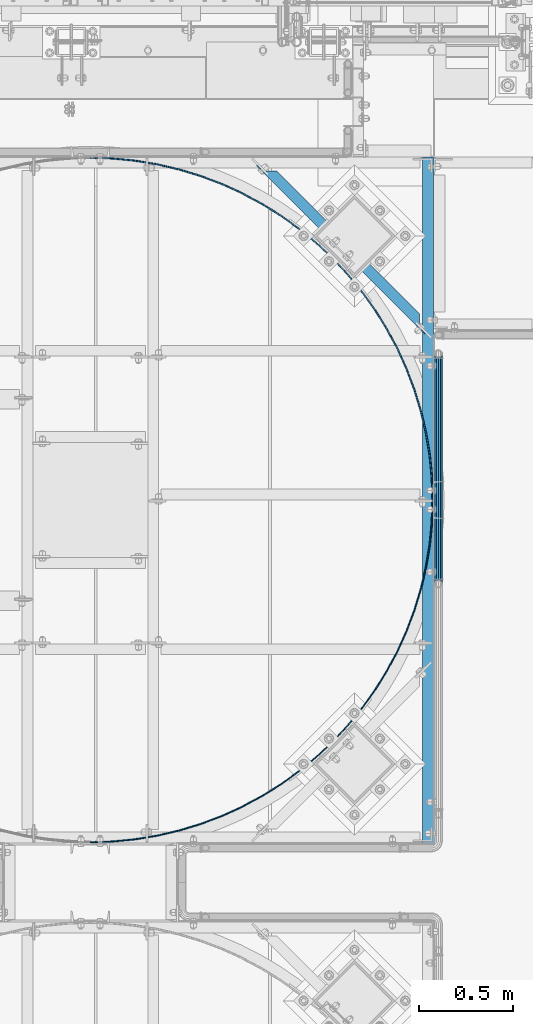
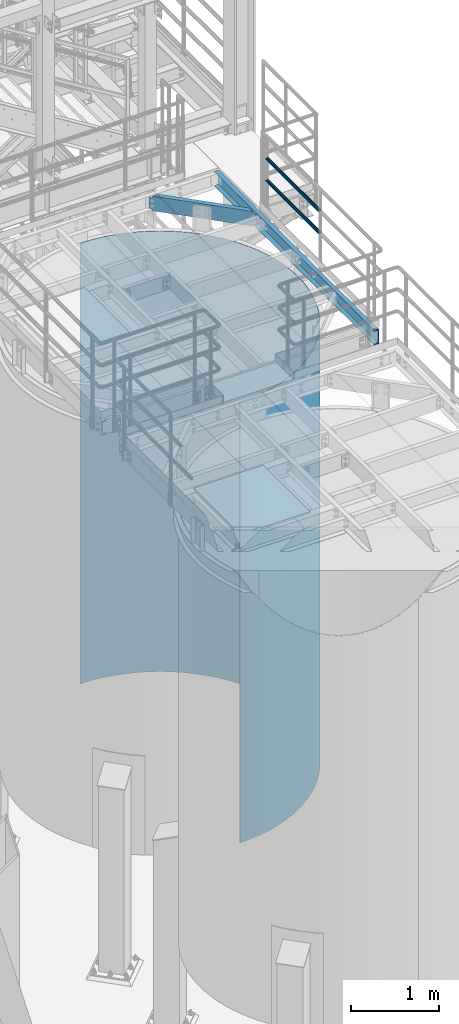
# One storey, part 942 of 1876: 5 beams, 4 elements without a shape of their own.
"""IFC2X3 building model written with IfcOpenShell, lengths in millimetres."""

import ifcopenshell
import ifcopenshell.guid

model = None  # the IFC model being written
_history = None  # IfcOwnerHistory: only IFC2X3 demands one
_inside = {}  # id of a spatial element -> (the spatial element, [elements in it])
_under = {}  # id of a project, library or spatial element -> (it, [spatial elements below it])
_declared = {}  # id of a project -> (the project, [libraries it declares])
_typed = {}  # id of a type object -> (the type object, [elements of that type])
_made_of = {}  # id of a material, layer set ... -> (it, [elements and type objects made of it])


def new_model(schema):
    """Start an empty IFC model of exactly this schema.

    Asked for "IFC4X3", IfcOpenShell would pick the latest addendum, in which some entities
    have other attributes; the version numbers below select the first issue.
    IFC2X3 requires an IfcOwnerHistory on every rooted entity: one is made here for all.
    """
    global model, _history
    if schema == "IFC4X3":
        model = ifcopenshell.file(schema_version=(4, 3, 0, 0))
    else:
        model = ifcopenshell.file(schema=schema)
    _inside.clear()
    _under.clear()
    _declared.clear()
    _typed.clear()
    _made_of.clear()
    _history = None
    if model.schema == "IFC2X3":
        org = make("IfcOrganization", Name="unknown")
        user = make(
            "IfcPersonAndOrganization",
            ThePerson=make("IfcPerson", FamilyName="unknown"),
            TheOrganization=org,
        )
        app = make(
            "IfcApplication",
            ApplicationDeveloper=org,
            Version="unknown",
            ApplicationFullName="unknown",
            ApplicationIdentifier="unknown",
        )
        _history = make(
            "IfcOwnerHistory",
            OwningUser=user,
            OwningApplication=app,
            ChangeAction="ADDED",
            CreationDate=0,
        )
    return model


def make(cls, **values):
    """One entity of the class cls with the attributes given. An attribute that is None is left unset."""
    return model.create_entity(
        cls, **{name: value for name, value in values.items() if value is not None}
    )


def rooted(cls, **values):
    """An entity with a GlobalId (a new one), such as an element, a storey or a relation."""
    return make(cls, GlobalId=ifcopenshell.guid.new(), OwnerHistory=_history, **values)


def si_unit(unit_type, name, prefix=None):
    """IfcSIUnit, for example si_unit("LENGTHUNIT", "METRE", prefix="MILLI")."""
    return make("IfcSIUnit", UnitType=unit_type, Prefix=prefix, Name=name)


def assignment(units):
    """IfcUnitAssignment: the units of a project."""
    return None if units is None else make("IfcUnitAssignment", Units=units)


def point(xyz):
    """IfcCartesianPoint."""
    return None if xyz is None else make("IfcCartesianPoint", Coordinates=xyz)


def direction(xyz):
    """IfcDirection."""
    return None if xyz is None else make("IfcDirection", DirectionRatios=xyz)


def frame(location, z_axis=None, x_axis=None):
    """IfcAxis2Placement3D, a coordinate frame: its origin and axes. An axis left out is left unset."""
    return make(
        "IfcAxis2Placement3D",
        Location=point(location),
        Axis=direction(z_axis),
        RefDirection=direction(x_axis),
    )


def origin_with_axes():
    """The frame at (0, 0, 0) with the z axis (0, 0, 1) and the x axis (1, 0, 0) written out."""
    return frame((0.0, 0.0, 0.0), z_axis=(0.0, 0.0, 1.0), x_axis=(1.0, 0.0, 0.0))


def place(relative_to, where):
    """IfcLocalPlacement: puts the frame where relative to a parent placement (None: the world)."""
    return make(
        "IfcLocalPlacement", PlacementRelTo=relative_to, RelativePlacement=where
    )


def context(
    kind, dimensions, precision=None, world=None, true_north=None, identifier=None
):
    """IfcGeometricRepresentationContext, for example the 3D "Model" context."""
    return make(
        "IfcGeometricRepresentationContext",
        ContextIdentifier=identifier,
        ContextType=kind,
        CoordinateSpaceDimension=dimensions,
        Precision=precision,
        WorldCoordinateSystem=world,
        TrueNorth=true_north,
    )


def subcontext(parent, identifier, kind, view, scale=None):
    """IfcGeometricRepresentationSubContext, for example "Body" below "Model"."""
    return make(
        "IfcGeometricRepresentationSubContext",
        ContextIdentifier=identifier,
        ContextType=kind,
        ParentContext=parent,
        TargetScale=scale,
        TargetView=view,
    )


def project(units=None, contexts=None):
    """IfcProject with its units and contexts."""
    return rooted(
        "IfcProject",
        Name="project",
        RepresentationContexts=contexts,
        UnitsInContext=assignment(units),
    )


def spatial(cls, under=None, at=None, **own):
    """A site, building, storey or space (cls), placed at a placement, below another one or the project."""
    s = rooted(cls, ObjectPlacement=at, **own)
    if under is not None:
        _under.setdefault(under.id(), (under, []))[1].append(s)
    return s


def faces_of(points, faces, orient=None, outer=None):
    """IfcFace entities. A face is a list of loops; a loop is a list of indices into points, from 0.

    orient and outer hold one flag for each loop. By default every Orientation is true, the
    first loop of a face is its IfcFaceOuterBound and the others are IfcFaceBound.
    """
    made = []
    for i, loops in enumerate(faces):
        bounds = []
        for j, loop in enumerate(loops):
            is_outer = j == 0 if outer is None else outer[i][j]
            bounds.append(
                make(
                    "IfcFaceOuterBound" if is_outer else "IfcFaceBound",
                    Bound=make("IfcPolyLoop", Polygon=[points[k] for k in loop]),
                    Orientation=True if orient is None else orient[i][j],
                )
            )
        made.append(make("IfcFace", Bounds=bounds))
    return made


def faceted_brep(points, faces, orient=None, outer=None, voids=None):
    """IfcFacetedBrep: a solid bounded by flat faces; with voids (closed shells), ...WithVoids."""
    shared = [point(p) for p in points]
    hull = make("IfcClosedShell", CfsFaces=faces_of(shared, faces, orient, outer))
    if voids is None:
        return make("IfcFacetedBrep", Outer=hull)
    return make(
        "IfcFacetedBrepWithVoids",
        Outer=hull,
        Voids=[
            make(cls, CfsFaces=faces_of(shared, fs, o, b)) for cls, fs, o, b in voids
        ],
    )


def shape(context_of_items, identifier, shape_type, items):
    """IfcShapeRepresentation: the items that make up one representation, for example the "Body"."""
    return make(
        "IfcShapeRepresentation",
        ContextOfItems=context_of_items,
        RepresentationIdentifier=identifier,
        RepresentationType=shape_type,
        Items=items,
    )


def material(Name=None, Category=None):
    """IfcMaterial."""
    return make("IfcMaterial", Name=Name, Category=Category)


def made_of(thing, what):
    """Note that an element or type object is made of a material, layer set ...; save() writes the relation."""
    if what is not None:
        _made_of.setdefault(what.id(), (what, []))[1].append(thing)
    return thing


def type_object(cls, material=None, **own):
    """A type object (cls), such as IfcWallType, which elements share."""
    return made_of(rooted(cls, **own), material)


def element(
    cls,
    number,
    at=None,
    inside=None,
    cuts=None,
    type_object=None,
    material=None,
    context=None,
    identifier="Body",
    shape_type=None,
    held_by="IfcProductDefinitionShape",
    body=None,
    shapes=None,
    **own,
):
    """One element of the class cls, such as IfcWall. Its Tag is "e" and its number.

    at: its placement. inside: the storey or other place that contains it. cuts: it is an
    opening in that element (IfcRelVoidsElement). A single representation is given by context,
    identifier, shape_type and body (its items); several are given by shapes. held_by: the class
    of the entity that holds the representations. save() writes the other relations.
    """
    e = rooted(cls, Tag="e%d" % number, ObjectPlacement=at, **own)
    if body is not None:
        shapes = [shape(context, identifier, shape_type, body)]
    if shapes is not None:
        e.Representation = make(held_by, Representations=shapes)
    if inside is not None:
        _inside.setdefault(inside.id(), (inside, []))[1].append(e)
    if cuts is not None:
        rooted(
            "IfcRelVoidsElement", RelatingBuildingElement=cuts, RelatedOpeningElement=e
        )
    if type_object is not None:
        _typed.setdefault(type_object.id(), (type_object, []))[1].append(e)
    return made_of(e, material)


def aggregate(whole, parts):
    """IfcRelAggregates: a whole, such as a stair, and the parts it consists of."""
    return rooted("IfcRelAggregates", RelatingObject=whole, RelatedObjects=parts)


def save(model, path):
    """Write the relations noted so far, then the file.

    IfcRelAggregates (storeys below a building ...), IfcRelContainedInSpatialStructure (elements
    in a storey), IfcRelDefinesByType, IfcRelAssociatesMaterial and IfcRelDeclares: one each for
    every whole, place, type object, material and project.
    """
    for whole, parts in _under.values():
        aggregate(whole, parts)
    for where, things in _inside.values():
        rooted(
            "IfcRelContainedInSpatialStructure",
            RelatedElements=things,
            RelatingStructure=where,
        )
    for kind, things in _typed.values():
        rooted("IfcRelDefinesByType", RelatedObjects=things, RelatingType=kind)
    for what, things in _made_of.values():
        rooted("IfcRelAssociatesMaterial", RelatedObjects=things, RelatingMaterial=what)
    for by, libraries in _declared.values():
        rooted("IfcRelDeclares", RelatingContext=by, RelatedDefinitions=libraries)
    model.write(path)


model = new_model("IFC2X3")

# Units and contexts
model_context = context("Model", 3, precision=1e-05, world=origin_with_axes())
body_context = subcontext(model_context, "Body", "Model", "MODEL_VIEW")
ifc_project = project(units=[si_unit("LENGTHUNIT", "METRE", prefix="MILLI"), si_unit("AREAUNIT", "SQUARE_METRE"), si_unit("VOLUMEUNIT", "CUBIC_METRE"), si_unit("MASSUNIT", "GRAM", prefix="KILO"), si_unit("TIMEUNIT", "SECOND"), si_unit("PLANEANGLEUNIT", "RADIAN"), si_unit("SOLIDANGLEUNIT", "STERADIAN"), si_unit("THERMODYNAMICTEMPERATUREUNIT", "DEGREE_CELSIUS"), si_unit("LUMINOUSINTENSITYUNIT", "LUMEN")], contexts=[model_context])

# Site, building, storey
site_placement = place(None, origin_with_axes())
site = spatial("IfcSite", under=ifc_project, at=site_placement, CompositionType="ELEMENT")
building_placement = place(site_placement, origin_with_axes())
building = spatial("IfcBuilding", under=site, at=building_placement, Name="Undefined", CompositionType="ELEMENT")
storey_placement = place(building_placement, origin_with_axes())
storey = spatial("IfcBuildingStorey", under=building, at=storey_placement, Name="Undefined", CompositionType="ELEMENT", Elevation=0.0)

# Assembly, beams
assembly_1_placement = place(storey_placement, origin_with_axes())
assembly_1 = element("IfcElementAssembly", 1, at=assembly_1_placement, inside=storey, Name="HANDRAIL", AssemblyPlace="NOTDEFINED", PredefinedType="RIGID_FRAME")
ifc_material_1 = material()
beam_type_1 = type_object("IfcBeamType", Name="PIPE1-1/4STD", PredefinedType="NOTDEFINED")
beam_1_placement = place(assembly_1_placement, frame((7025.13388293519, -9982.16435546873, 8480.425), z_axis=(0.0, 0.0, 1.0), x_axis=(0.0, 1.0, 0.0)))
beam_1 = element("IfcBeam", 2, at=beam_1_placement, type_object=beam_type_1, material=ifc_material_1, Name="RAIL", ObjectType="PIPE1-1/4STD", context=body_context, shape_type="Brep", body=[
    faceted_brep([(1200.94245243742, -10.5409999999993, 18.2575475625836), (1200.94245243742, -10.5409999999993, 13.3999612267253), (1200.46603877327, -8.76300000000083, 15.1779612267255), (1198.118, 0.0, 17.5259999999998), (1198.118, 0.0, 21.0820000000003), (1200.46603877327, 8.76300000000083, 15.1779612267255), (1200.94245243742, 10.5409999999993, 13.3999612267253), (1200.94245243742, 10.5409999999993, 18.2575475625836), (1219.2, 21.0820000000003, 0.0), (1208.659, 18.2575475625836, 10.5409999999993), (1208.659, 18.2575475625836, -10.5409999999993), (1205.57941366414, 15.1779612267255, 8.76300000000083), (1207.92745243742, 17.5259999999998, 0.0), (1205.57941366414, 15.1779612267255, -8.76300000000083), (1200.94245243742, 10.5409999999993, -13.3999612267253), (1200.94245243742, 10.5409999999993, -18.2575475625836), (1200.46603877327, 8.76300000000083, -15.1779612267255), (1198.118, 0.0, -17.5259999999998), (1198.118, 0.0, -21.0820000000003), (1200.94245243742, -10.5409999999993, -13.3999612267253), (1200.94245243742, -10.5409999999993, -18.2575475625836), (1200.46603877327, -8.76300000000083, -15.1779612267255), (1219.2, -21.0820000000003, 0.0), (1208.659, -18.2575475625836, -10.5409999999993), (1208.659, -18.2575475625836, 10.5409999999993), (1205.57941366414, -15.1779612267255, -8.76300000000083), (1207.92745243742, -17.5259999999998, 0.0), (1205.57941366414, -15.1779612267255, 8.76300000000083), (10.5409999957128, -18.2575475672238, -10.5409999999993), (18.2575475625817, -10.5410000000011, -18.2575475625836), (9.09494701772928e-13, 21.0820000000003, 0.0), (10.5409999957128, 18.2575475579433, -10.5409999999993), (10.5409999999983, 18.2575475625836, 10.5410000000011), (18.2575475625817, 10.5409999999993, 18.2575475625836), (21.0819999999985, 1.81898940354586e-12, 21.0820000000003), (18.2575475625817, 10.5409999999993, -18.2575475625836), (21.0819999999985, 0.0, -21.0819999999985), (21.0819999999985, 0.0, -17.5259999999998), (18.2575475625817, -10.5409999999974, -13.3999612267271), (18.7339612267233, -8.76300000000083, -15.1779612267255), (18.7339612267251, 8.76299999999901, -15.1779612267255), (18.2575475625817, 10.5410000000011, -13.3999612267235), (13.6205863358573, 15.1779612267255, -8.76299999999901), (11.2725475625839, 17.5259999999998, 0.0), (13.6205863358573, 15.1779612267255, 8.76300000000083), (18.2575475625817, 10.5410000000011, 13.3999612267253), (18.7339612267251, 8.76299999999901, 15.1779612267273), (21.0819999999985, 1.81898940354586e-12, 17.5259999999998), (18.7339612267233, -8.76300000000083, 15.1779612267273), (18.2575475625817, -10.5409999999974, 13.3999612267289), (18.2575475625817, -10.5410000000011, 18.2575475625836), (10.5409999999983, -18.2575475625836, 10.5410000000011), (9.09494701772928e-13, -21.0820000000003, 0.0), (13.6205863358537, -15.1779612267255, 8.76300000000083), (11.2725475625793, -17.5259999999998, 0.0), (13.6205863358537, -15.1779612267255, -8.76299999999901)], [[[0, 1, 2, 3, 4]], [[4, 3, 5, 6, 7]], [[8, 9, 10]], [[7, 6, 11, 12, 13, 14, 15, 10, 9]], [[16, 17, 18, 15, 14]], [[19, 20, 18, 17, 21]], [[22, 23, 24]], [[24, 23, 20, 19, 25, 26, 27, 1, 0]], [[28, 29, 20, 23]], [[30, 31, 32]], [[33, 34, 4, 7]], [[32, 33, 7, 9]], [[30, 32, 9, 8]], [[31, 30, 8, 10]], [[35, 31, 10, 15]], [[36, 35, 15, 18]], [[29, 36, 18, 20]], [[37, 36, 29, 38, 39]], [[40, 41, 35, 36, 37]], [[32, 31, 35, 41, 42, 43, 44, 45, 33]], [[33, 45, 46, 47, 34]], [[34, 47, 48, 49, 50]], [[34, 50, 0, 4]], [[50, 51, 24, 0]], [[51, 52, 22, 24]], [[52, 28, 23, 22]], [[51, 28, 52]], [[50, 49, 53, 54, 55, 38, 29, 28, 51]], [[55, 54, 26, 25]], [[21, 39, 38, 55, 25, 19]], [[37, 39, 21, 17]], [[40, 37, 17, 16]], [[42, 41, 40, 16, 14, 13]], [[43, 42, 13, 12]], [[44, 43, 12, 11]], [[5, 46, 45, 44, 11, 6]], [[47, 46, 5, 3]], [[48, 47, 3, 2]], [[53, 49, 48, 2, 1, 27]], [[54, 53, 27, 26]]]),
])
beam_2_placement = place(assembly_1_placement, frame((7025.13388293519, -8762.96435546873, 8785.225), z_axis=(0.0, 0.0, -1.0), x_axis=(0.0, -1.0, 0.0)))
beam_2 = element("IfcBeam", 3, at=beam_2_placement, type_object=beam_type_1, material=ifc_material_1, Name="RAIL", ObjectType="PIPE1-1/4STD", context=body_context, shape_type="Brep", body=[
    faceted_brep([(9.09494701772928e-13, 21.0820000000003, 0.0), (10.5409999957128, 18.2575475579433, -10.5409999999993), (10.5409999999983, 18.2575475625836, 10.5410000000011), (10.5409999999983, -18.2575475625836, 10.5410000000011), (10.5409999957128, -18.2575475672238, -10.5409999999993), (9.09494701772928e-13, -21.0820000000003, 0.0), (18.2575475625817, -10.5410000000011, 18.2575475625836), (18.2575475625817, -10.5409999999974, 13.3999612267289), (13.6205863358537, -15.1779612267255, 8.76300000000083), (11.2725475625793, -17.5259999999998, 0.0), (13.6205863358537, -15.1779612267255, -8.76299999999901), (18.2575475625817, -10.5409999999974, -13.3999612267271), (18.2575475625817, -10.5410000000011, -18.2575475625836), (21.0819999999985, 0.0, -17.5259999999998), (21.0819999999985, 0.0, -21.0819999999985), (18.7339612267233, -8.76300000000083, -15.1779612267255), (18.7339612267251, 8.76299999999901, -15.1779612267255), (18.2575475625817, 10.5410000000011, -13.3999612267235), (18.2575475625817, 10.5409999999993, -18.2575475625836), (13.6205863358573, 15.1779612267255, -8.76299999999901), (11.2725475625839, 17.5259999999998, 0.0), (13.6205863358573, 15.1779612267255, 8.76300000000083), (18.2575475625817, 10.5410000000011, 13.3999612267253), (18.2575475625817, 10.5409999999993, 18.2575475625836), (18.7339612267251, 8.76299999999901, 15.1779612267273), (21.0819999999985, 1.81898940354586e-12, 17.5259999999998), (21.0819999999985, 1.81898940354586e-12, 21.0820000000003), (18.7339612267233, -8.76300000000083, 15.1779612267273), (1219.2, 21.0820000000003, 0.0), (1208.659, 18.2575475625836, -10.5409999999993), (1200.94245243742, 10.5409999999993, -18.2575475625836), (1219.2, -21.0820000000003, 0.0), (1208.659, -18.2575475625836, -10.5409999999993), (1208.659, -18.2575475625836, 10.5409999999993), (1200.94245243742, -10.5409999999993, 18.2575475625836), (1200.94245243742, -10.5409999999993, -18.2575475625836), (1198.118, 0.0, -21.0820000000003), (1200.46603877327, 8.76300000000083, -15.1779612267255), (1198.118, 0.0, -17.5259999999998), (1200.94245243742, 10.5409999999993, -13.3999612267253), (1200.94245243742, -10.5409999999993, -13.3999612267253), (1200.46603877327, -8.76300000000083, -15.1779612267255), (1205.57941366414, -15.1779612267255, -8.76300000000083), (1207.92745243742, -17.5259999999998, 0.0), (1205.57941366414, -15.1779612267255, 8.76300000000083), (1200.94245243742, -10.5409999999993, 13.3999612267253), (1200.46603877327, -8.76300000000083, 15.1779612267255), (1198.118, 0.0, 17.5259999999998), (1198.118, 0.0, 21.0820000000003), (1200.94245243742, 10.5409999999993, 18.2575475625836), (1208.659, 18.2575475625836, 10.5409999999993), (1200.94245243742, 10.5409999999993, 13.3999612267253), (1205.57941366414, 15.1779612267255, 8.76300000000083), (1207.92745243742, 17.5259999999998, 0.0), (1205.57941366414, 15.1779612267255, -8.76300000000083), (1200.46603877327, 8.76300000000083, 15.1779612267255)], [[[0, 1, 2]], [[3, 4, 5]], [[6, 7, 8, 9, 10, 11, 12, 4, 3]], [[13, 14, 12, 11, 15]], [[16, 17, 18, 14, 13]], [[2, 1, 18, 17, 19, 20, 21, 22, 23]], [[23, 22, 24, 25, 26]], [[26, 25, 27, 7, 6]], [[1, 0, 28, 29]], [[18, 1, 29, 30]], [[31, 32, 33]], [[6, 3, 33, 34]], [[3, 5, 31, 33]], [[5, 4, 32, 31]], [[4, 12, 35, 32]], [[12, 14, 36, 35]], [[14, 18, 30, 36]], [[37, 38, 36, 30, 39]], [[40, 35, 36, 38, 41]], [[33, 32, 35, 40, 42, 43, 44, 45, 34]], [[34, 45, 46, 47, 48]], [[26, 6, 34, 48]], [[2, 23, 49, 50]], [[23, 26, 48, 49]], [[0, 2, 50, 28]], [[28, 50, 29]], [[49, 51, 52, 53, 54, 39, 30, 29, 50]], [[48, 47, 55, 51, 49]], [[25, 24, 55, 47]], [[55, 24, 22, 21, 52, 51]], [[21, 20, 53, 52]], [[20, 19, 54, 53]], [[19, 17, 16, 37, 39, 54]], [[16, 13, 38, 37]], [[13, 15, 41, 38]], [[41, 15, 11, 10, 42, 40]], [[10, 9, 43, 42]], [[9, 8, 44, 43]], [[8, 7, 27, 46, 45, 44]], [[27, 25, 47, 46]]]),
])
aggregate(assembly_1, [beam_1, beam_2])

# Assembly, beam
assembly_2_placement = place(storey_placement, origin_with_axes())
assembly_2 = element("IfcElementAssembly", 4, at=assembly_2_placement, inside=storey, Name="BEAM", AssemblyPlace="NOTDEFINED", PredefinedType="RIGID_FRAME")
ifc_material_2 = material(Name="STEEL/A36")
beam_type_2 = type_object("IfcBeamType", Name="C8X11.5", PredefinedType="NOTDEFINED")
beam_3_placement = place(assembly_2_placement, frame((6039.01386511983, -7705.32757802322, 7896.225), z_axis=(0.0, 0.0, -1.0), x_axis=(0.707106781186547, -0.707106781186548, 0.0)))
beam_3 = element("IfcBeam", 5, at=beam_3_placement, type_object=beam_type_2, material=ifc_material_2, Name="BEAM", ObjectType="C8X11.5", context=body_context, shape_type="Brep", body=[
    faceted_brep([(1223.93966372655, -28.5750000000035, -101.6), (1223.93966372655, -28.5750000000035, -96.8355949999996), (154.81028315886, -28.5750000000044, -96.8355949999996), (154.81028315886, -28.5750000000044, -101.6), (1271.57228792066, 19.0576241941089, -88.8999998092622), (1274.88810387369, 22.225000000004, -88.3723149999996), (103.861843011711, 22.225000000004, -88.3723149999996), (107.177658964769, 19.0576241940862, -88.8999998092659), (86.0497711864464, 22.225000000004, -76.2000000000007), (79.6997711864442, 28.5750000000053, -76.2000000000007), (86.572961555079, 28.5750000000053, -77.1667299225883), (92.9229615550812, 22.225000000004, -77.1667299225883), (92.3997709957148, 28.5750000000053, -79.9197438230667), (98.7497709957152, 22.225000000004, -79.9197438230667), (96.2931205911736, 28.5750000000053, -84.0399202912204), (102.643120591174, 22.2250000000049, -84.0399202912204), (97.6602831588498, 28.5750000000053, -88.8999998092659), (97.6602831588498, 28.5750000000053, -101.6), (1281.08966372656, 28.5750000000062, -101.6), (1281.08966372656, 28.5750000000062, -88.8999998092622), (1282.45682629424, 28.5750000000044, -84.0399202912167), (1276.10682629423, 22.2250000000031, -84.0399202912167), (1286.35017588969, 28.5750000000062, -79.9197438230631), (1280.00017588969, 22.2250000000049, -79.9197438230631), (1292.17698533033, 28.5750000000062, -77.1667299225846), (1285.82698533033, 22.2250000000049, -77.1667299225846), (1299.05017569896, 28.5750000000053, -76.1999999999971), (1292.70017569896, 22.225000000004, -76.1999999999971), (1319.3218385947, 28.5750000000053, -76.1999999999971), (1319.3218385947, 22.225000000004, -76.1999999999971), (1319.3218385947, 28.5750000000053, 76.2000000000016), (1319.3218385947, 22.225000000004, 76.2000000000016), (1299.0501756976, 28.5750000000053, 76.2000000000016), (1292.7001756976, 22.2250000000049, 76.2000000000016), (1292.17698532897, 28.5750000000053, 77.1667299225892), (1285.82698532897, 22.225000000004, 77.1667299225892), (1286.35017588834, 28.5750000000053, 79.9197438230676), (1280.00017588834, 22.225000000004, 79.9197438230676), (1282.45682629288, 28.5750000000044, 84.0399202912213), (1276.10682629288, 22.225000000004, 84.0399202912213), (1281.0896637252, 28.5750000000053, 88.8999998092668), (1271.57228791927, 19.0576241940789, 88.8999998092668), (1274.88810387234, 22.2250000000049, 88.3723149999996), (1281.0896637252, 28.5750000000053, 101.6), (1223.93966372519, -28.5750000000044, 101.6), (1223.93966372519, -28.5750000000044, 96.8355949999996), (97.6602831589025, 28.5750000000062, 101.6), (154.810283158913, -28.5750000000035, 101.6), (154.810283158913, -28.5750000000035, 96.8355949999996), (103.861843011768, 22.2250000000049, 88.3723149999996), (107.177658964813, 19.0576241940971, 88.899999809264), (97.6602831589025, 28.5750000000062, 88.899999809264), (96.2931205912264, 28.5750000000053, 84.0399202912186), (102.643120591229, 22.225000000004, 84.0399202912186), (92.3997709957694, 28.5750000000053, 79.9197438230649), (98.7497709957697, 22.2250000000049, 79.9197438230649), (86.5729615551336, 28.5750000000062, 77.1667299225865), (92.922961555134, 22.2250000000049, 77.1667299225865), (79.6997711864988, 28.5750000000053, 76.1999999999989), (86.0497711865009, 22.225000000004, 76.1999999999989), (59.4281082869256, 22.225000000004, 76.1999999999989), (59.4281082869256, 22.225000000004, -76.2000000000007), (59.4281082869256, 28.5750000000062, -76.2000000000007), (59.4281082869256, 28.5750000000062, 76.1999999999989)], [[[0, 1, 2, 3]], [[1, 4, 5, 6, 7, 2]], [[8, 9, 10, 11]], [[11, 10, 12, 13]], [[13, 12, 14, 15]], [[6, 15, 14, 16, 7]], [[2, 7, 16, 17, 3]], [[18, 0, 3, 17]], [[19, 4, 1, 0, 18]], [[20, 21, 5, 4, 19]], [[22, 23, 21, 20]], [[24, 25, 23, 22]], [[26, 27, 25, 24]], [[27, 26, 28, 29]], [[28, 30, 31, 29]], [[32, 33, 31, 30]], [[34, 35, 33, 32]], [[36, 37, 35, 34]], [[38, 39, 37, 36]], [[40, 41, 42, 39, 38]], [[43, 44, 45, 41, 40]], [[44, 43, 46, 47]], [[45, 44, 47, 48]], [[49, 42, 41, 45, 48, 50]], [[47, 46, 51, 50, 48]], [[50, 51, 52, 53, 49]], [[53, 52, 54, 55]], [[55, 54, 56, 57]], [[57, 56, 58, 59]], [[8, 11, 13, 15, 6, 5, 21, 23, 25, 27, 29, 31, 33, 35, 37, 39, 42, 49, 53, 55, 57, 59, 60, 61]], [[9, 8, 61, 62]], [[58, 56, 54, 52, 51, 46, 43, 40, 38, 36, 34, 32, 30, 28, 26, 24, 22, 20, 19, 18, 17, 16, 14, 12, 10, 9, 62, 63]], [[59, 58, 63, 60]], [[62, 61, 60, 63]]]),
])
aggregate(assembly_2, [beam_3])

assembly_3_placement = place(storey_placement, origin_with_axes())
assembly_3 = element("IfcElementAssembly", 6, at=assembly_3_placement, inside=storey, Name="BEAM", AssemblyPlace="NOTDEFINED", PredefinedType="RIGID_FRAME")
beam_4_placement = place(assembly_3_placement, frame((6969.12547584742, -11353.7643554687, 7896.225), z_axis=(0.0, 0.0, -1.0), x_axis=(0.0, 1.0, 0.0)))
beam_4 = element("IfcBeam", 7, at=beam_4_placement, type_object=beam_type_2, material=ifc_material_2, Name="BEAM", ObjectType="C8X11.5", context=body_context, shape_type="Brep", body=[
    faceted_brep([(0.0, 28.5749999999998, -101.6), (0.0, 28.5749999999998, 101.6), (3632.1999511731, 28.5749999999998, 101.6), (3632.1999511731, 28.5749999999998, -101.6), (0.0, -28.5749999999998, 101.6), (3632.1999511731, -28.5749999999998, 101.6), (0.0, -28.5749999999998, 96.8355950000005), (3632.1999511731, -28.5749999999998, 96.8355949999996), (0.0, 22.2250000000004, 88.3723150000005), (3632.1999511731, 22.2250000000004, 88.3723149999996), (0.0, 22.2250000000004, -88.3723150000005), (3632.1999511731, 22.2250000000004, -88.3723149999996), (0.0, -28.5749999999998, -96.8355950000005), (3632.1999511731, -28.5749999999998, -96.8355949999996), (0.0, -28.5749999999998, -101.6), (3632.1999511731, -28.5749999999998, -101.6)], [[[0, 1, 2, 3]], [[1, 4, 5, 2]], [[4, 6, 7, 5]], [[6, 8, 9, 7]], [[8, 10, 11, 9]], [[10, 12, 13, 11]], [[12, 14, 15, 13]], [[14, 0, 3, 15]], [[5, 7, 9, 11, 13, 15, 3, 2]], [[14, 12, 10, 8, 6, 4, 1, 0]]]),
])
aggregate(assembly_3, [beam_4])

assembly_4_placement = place(storey_placement, origin_with_axes())
assembly_4 = element("IfcElementAssembly", 8, at=assembly_4_placement, inside=storey, Name="PLATE", AssemblyPlace="NOTDEFINED", PredefinedType="RIGID_FRAME")
beam_type_3 = type_object("IfcBeamType", PredefinedType="NOTDEFINED")
beam_5_placement = place(assembly_4_placement, frame((5179.35543623061, -11351.5192914385, 4572.0), z_axis=(0.0, 0.0, 1.0), x_axis=(0.707106781186548, 0.707106781186547, 0.0)))
beam_5 = element("IfcBeam", 9, at=beam_5_placement, type_object=beam_type_3, material=ifc_material_2, Name="PLATE", context=body_context, shape_type="Brep", body=[
    faceted_brep([(-9.09494701772928e-13, -3.17500000000109, -3048.0), (-9.09494701772928e-13, -3.17500000000109, 3048.0), (4.49012806053361, 1.31512806053615, 3048.0), (4.49012806053361, 1.31512806053615, -3048.0), (90.9255352695482, -79.640465180064, 3048.0), (90.9255352695482, -79.640465180064, -3048.0), (86.7386893436624, -84.4146479575556, -3048.0), (86.7386893436624, -84.4146479575556, 3048.0), (178.604991689236, -159.807373884372, -3048.0), (178.604991689236, -159.807373884372, 3048.0), (182.47062676344, -154.769580173521, 3048.0), (182.47062676344, -154.769580173521, -3048.0), (275.205521426504, -229.030334553527, -3048.0), (275.205521426504, -229.030334553527, 3048.0), (278.733392406178, -223.750502515404, 3048.0), (278.733392406177, -223.750502515404, -3048.0), (376.126620256749, -291.787106620137, -3048.0), (376.126620256749, -291.787106620137, 3048.0), (379.301620256748, -286.287845306104, 3048.0), (379.301620256748, -286.287845306104, -3048.0), (480.936128541091, -347.808955951614, -3048.0), (480.936128541091, -347.808955951614, 3048.0), (483.744661723981, -342.113814042879, 3048.0), (483.744661723981, -342.113814042879, -3048.0), (589.185235874409, -396.85598838849, -3048.0), (589.185235874409, -396.85598838849, 3048.0), (591.615275669926, -390.989353357043, 3048.0), (591.615275669926, -390.989353357043, -3048.0), (700.410402960397, -438.718177008037, -3048.0), (700.410402960397, -438.718177008037, 3048.0), (702.45154356507, -432.70517068574, 3048.0), (702.45154356507, -432.70517068574, -3048.0), (814.135346557992, -473.216261491782, -3048.0), (814.135346557992, -473.216261491782, 3048.0), (815.778847494393, -467.082632494845, 3048.0), (815.778847494393, -467.082632494845, -3048.0), (929.873078999343, -500.202515745726, -3048.0), (929.873078999343, -500.202515745726, 3048.0), (931.111902544145, -493.974529215166, 3048.0), (931.111902544145, -493.974529215166, -3048.0), (1047.12799354576, -519.561380486148, -3048.0), (1047.12799354576, -519.561380486148, 3048.0), (1047.95683486635, -513.265705616424, 3048.0), (1047.95683486635, -513.265705616424, -3048.0), (1165.39798665184, -531.209958082203, -3048.0), (1165.39798665184, -531.209958082203, 3048.0), (1165.81329652245, -524.873553919637, 3048.0), (1165.81329652245, -524.873553919637, -3048.0), (1284.17660804997, -535.098367536304, -3048.0), (1284.17660804997, -535.098367536304, 3048.0), (1284.17660804997, -528.748367536302, 3048.0), (1284.17660804997, -528.748367536302, -3048.0), (1402.95522944811, -531.209958082205, -3048.0), (1402.95522944811, -531.209958082205, 3048.0), (1402.5399195775, -524.873553919639, 3048.0), (1402.5399195775, -524.873553919639, -3048.0), (1521.22522255419, -519.56138048615, -3048.0), (1521.22522255419, -519.56138048615, 3048.0), (1520.39638123359, -513.265705616424, 3048.0), (1520.39638123359, -513.265705616424, -3048.0), (1638.4801371006, -500.202515745726, -3048.0), (1638.4801371006, -500.202515745726, 3048.0), (1637.2413135558, -493.974529215166, 3048.0), (1637.2413135558, -493.974529215166, -3048.0), (1754.21786954195, -473.216261491782, -3048.0), (1754.21786954195, -473.216261491782, 3048.0), (1752.57436860555, -467.082632494845, 3048.0), (1752.57436860555, -467.082632494845, -3048.0), (1867.94281313955, -438.718177008037, -3048.0), (1867.94281313955, -438.718177008037, 3048.0), (1865.90167253487, -432.705170685742, 3048.0), (1865.90167253487, -432.705170685742, -3048.0), (1979.16798022554, -396.85598838849, -3048.0), (1979.16798022554, -396.85598838849, 3048.0), (1976.73794043002, -390.989353357041, 3048.0), (1976.73794043002, -390.989353357041, -3048.0), (2087.41708755885, -347.808955951614, -3048.0), (2087.41708755885, -347.808955951614, 3048.0), (2084.60855437596, -342.113814042879, 3048.0), (2084.60855437596, -342.113814042879, -3048.0), (2192.2265958432, -291.787106620137, -3048.0), (2192.2265958432, -291.787106620137, 3048.0), (2189.0515958432, -286.287845306104, 3048.0), (2189.0515958432, -286.287845306104, -3048.0), (2293.14769467344, -229.030334553529, -3048.0), (2293.14769467344, -229.030334553529, 3048.0), (2289.61982369377, -223.750502515408, 3048.0), (2289.61982369377, -223.750502515408, -3048.0), (2389.74822441071, -159.807373884372, -3048.0), (2389.74822441071, -159.807373884372, 3048.0), (2385.8825893365, -154.769580173523, 3048.0), (2385.8825893365, -154.769580173523, -3048.0), (2481.61452675628, -84.4146479575593, -3048.0), (2481.61452675628, -84.4146479575593, 3048.0), (2477.4276808304, -79.640465180064, 3048.0), (2477.4276808304, -79.640465180064, -3048.0), (2568.35321609995, -3.17500000000109, -3048.0), (2568.35321609995, -3.17500000000109, 3048.0), (2563.86308803941, 1.31512806053615, 3048.0), (2563.86308803941, 1.31512806053615, -3048.0), (2724.98558998438, 175.429991689211, 3048.0), (2794.20855065356, 272.030521426468, 3048.0), (2856.9653227202, 372.951620256708, 3048.0), (2912.9871720517, 477.761128541046, 3048.0), (2962.0342044886, 586.010235874362, 3048.0), (3003.89639310817, 697.235402960352, 3048.0), (3038.39447759193, 810.960346557951, 3048.0), (3065.38073184589, 926.698078999309, 3048.0), (3084.73959658633, 1043.95299354573, 3048.0), (3096.3881741824, 1162.22298665182, 3048.0), (3100.27658363651, 1281.00160804996, 3048.0), (3096.38817418241, 1399.78022944811, 3048.0), (3084.73959658636, 1518.0502225542, 3048.0), (3065.38073184594, 1635.30513710062, 3048.0), (3038.394477592, 1751.04286954198, 3048.0), (3003.89639310825, 1864.76781313958, 3048.0), (2962.0342044887, 1975.99298022558, 3048.0), (2912.98717205181, 2084.2420875589, 3048.0), (2856.96532272032, 2189.05159584325, 3048.0), (2794.2085506537, 2289.9726946735, 3048.0), (2724.98558998453, 2386.57322441077, 3048.0), (2649.5928640577, 2478.43952675634, 3048.0), (2568.35321610013, 2565.1782161, 3048.0), (2563.86308803959, 2560.68808803946, 3048.0), (2644.8186812802, 2474.25268083045, 3048.0), (2719.94779627368, 2382.70758933656, 3048.0), (2788.92871861558, 2286.44482369382, 3048.0), (2851.46606140629, 2185.87659584325, 3048.0), (2907.29203014307, 2081.43355437601, 3048.0), (2956.16756945725, 1973.56294043006, 3048.0), (2997.88338678595, 1862.72667253491, 3048.0), (3032.26084859506, 1749.39936860558, 3048.0), (3059.15274531538, 1634.06631355582, 3048.0), (3078.44392171664, 1517.2213812336, 3048.0), (3090.05177001985, 1399.36491957749, 3048.0), (3093.9265836365, 1281.00160804996, 3048.0), (3090.05177001983, 1162.63829652243, 3048.0), (3078.4439217166, 1044.78183486632, 3048.0), (3059.15274531533, 927.93690254411, 3048.0), (3032.26084859499, 812.603847494354, 3048.0), (2997.88338678587, 699.276543565027, 3048.0), (2956.16756945715, 588.440275669882, 3048.0), (2907.29203014296, 480.569661723937, 3048.0), (2851.46606140616, 376.126620256708, 3048.0), (2788.92871861544, 275.558392406143, 3048.0), (2719.94779627353, 179.295626763416, 3048.0), (2644.81868128004, 87.7505352695352, 3048.0), (2649.59286405753, 83.5636893436476, 3048.0), (2644.81868128004, 87.7505352695352, -3048.0), (2719.94779627353, 179.295626763416, -3048.0), (2788.92871861544, 275.558392406143, -3048.0), (2851.46606140616, 376.126620256708, -3048.0), (2907.29203014296, 480.569661723937, -3048.0), (2956.16756945715, 588.440275669882, -3048.0), (2997.88338678587, 699.276543565027, -3048.0), (3032.26084859499, 812.603847494354, -3048.0), (3059.15274531533, 927.93690254411, -3048.0), (3078.4439217166, 1044.78183486632, -3048.0), (3090.05177001983, 1162.63829652243, -3048.0), (3093.9265836365, 1281.00160804996, -3048.0), (3090.05177001985, 1399.36491957749, -3048.0), (3078.44392171664, 1517.2213812336, -3048.0), (3059.15274531538, 1634.06631355582, -3048.0), (3032.26084859506, 1749.39936860558, -3048.0), (2997.88338678595, 1862.72667253491, -3048.0), (2956.16756945725, 1973.56294043006, -3048.0), (2907.29203014307, 2081.43355437601, -3048.0), (2851.46606140629, 2185.87659584325, -3048.0), (2788.92871861558, 2286.44482369382, -3048.0), (2719.94779627368, 2382.70758933656, -3048.0), (2644.8186812802, 2474.25268083045, -3048.0), (2563.86308803959, 2560.68808803946, -3048.0), (2568.35321610013, 2565.1782161, -3048.0), (2649.5928640577, 2478.43952675634, -3048.0), (2724.98558998453, 2386.57322441077, -3048.0), (2794.2085506537, 2289.9726946735, -3048.0), (2856.96532272032, 2189.05159584325, -3048.0), (2912.98717205181, 2084.2420875589, -3048.0), (2962.0342044887, 1975.99298022558, -3048.0), (3003.89639310825, 1864.76781313958, -3048.0), (3038.394477592, 1751.04286954198, -3048.0), (3065.38073184594, 1635.30513710062, -3048.0), (3084.73959658636, 1518.0502225542, -3048.0), (3096.38817418241, 1399.78022944811, -3048.0), (3100.27658363651, 1281.00160804996, -3048.0), (3096.3881741824, 1162.22298665182, -3048.0), (3084.73959658633, 1043.95299354573, -3048.0), (3065.38073184589, 926.698078999309, -3048.0), (3038.39447759193, 810.960346557951, -3048.0), (3003.89639310817, 697.235402960352, -3048.0), (2962.0342044886, 586.010235874362, -3048.0), (2912.9871720517, 477.761128541046, -3048.0), (2856.9653227202, 372.951620256708, -3048.0), (2794.20855065356, 272.030521426468, -3048.0), (2724.98558998438, 175.429991689211, -3048.0), (2649.59286405753, 83.5636893436476, -3048.0)], [[[0, 1, 2, 3]], [[3, 2, 4, 5]], [[1, 0, 6, 7]], [[6, 8, 9, 7]], [[4, 10, 11, 5]], [[8, 12, 13, 9]], [[10, 14, 15, 11]], [[12, 16, 17, 13]], [[14, 18, 19, 15]], [[16, 20, 21, 17]], [[18, 22, 23, 19]], [[20, 24, 25, 21]], [[22, 26, 27, 23]], [[24, 28, 29, 25]], [[26, 30, 31, 27]], [[28, 32, 33, 29]], [[30, 34, 35, 31]], [[32, 36, 37, 33]], [[34, 38, 39, 35]], [[36, 40, 41, 37]], [[38, 42, 43, 39]], [[40, 44, 45, 41]], [[42, 46, 47, 43]], [[44, 48, 49, 45]], [[46, 50, 51, 47]], [[48, 52, 53, 49]], [[50, 54, 55, 51]], [[52, 56, 57, 53]], [[54, 58, 59, 55]], [[56, 60, 61, 57]], [[58, 62, 63, 59]], [[60, 64, 65, 61]], [[62, 66, 67, 63]], [[64, 68, 69, 65]], [[66, 70, 71, 67]], [[68, 72, 73, 69]], [[70, 74, 75, 71]], [[72, 76, 77, 73]], [[74, 78, 79, 75]], [[76, 80, 81, 77]], [[78, 82, 83, 79]], [[80, 84, 85, 81]], [[82, 86, 87, 83]], [[84, 88, 89, 85]], [[86, 90, 91, 87]], [[88, 92, 93, 89]], [[90, 94, 95, 91]], [[92, 96, 97, 93]], [[94, 98, 99, 95]], [[100, 101, 102, 103, 104, 105, 106, 107, 108, 109, 110, 111, 112, 113, 114, 115, 116, 117, 118, 119, 120, 121, 122, 123, 124, 125, 126, 127, 128, 129, 130, 131, 132, 133, 134, 135, 136, 137, 138, 139, 140, 141, 142, 143, 144, 145, 146, 98, 94, 90, 86, 82, 78, 74, 70, 66, 62, 58, 54, 50, 46, 42, 38, 34, 30, 26, 22, 18, 14, 10, 4, 2, 1, 7, 9, 13, 17, 21, 25, 29, 33, 37, 41, 45, 49, 53, 57, 61, 65, 69, 73, 77, 81, 85, 89, 93, 97, 147]], [[99, 98, 146, 148]], [[149, 150, 151, 152, 153, 154, 155, 156, 157, 158, 159, 160, 161, 162, 163, 164, 165, 166, 167, 168, 169, 170, 171, 172, 173, 174, 175, 176, 177, 178, 179, 180, 181, 182, 183, 184, 185, 186, 187, 188, 189, 190, 191, 192, 193, 194, 195, 96, 92, 88, 84, 80, 76, 72, 68, 64, 60, 56, 52, 48, 44, 40, 36, 32, 28, 24, 20, 16, 12, 8, 6, 0, 3, 5, 11, 15, 19, 23, 27, 31, 35, 39, 43, 47, 51, 55, 59, 63, 67, 71, 75, 79, 83, 87, 91, 95, 99, 148]], [[97, 96, 195, 147]], [[195, 194, 100, 147]], [[146, 145, 149, 148]], [[194, 193, 101, 100]], [[145, 144, 150, 149]], [[193, 192, 102, 101]], [[144, 143, 151, 150]], [[192, 191, 103, 102]], [[143, 142, 152, 151]], [[191, 190, 104, 103]], [[142, 141, 153, 152]], [[190, 189, 105, 104]], [[141, 140, 154, 153]], [[189, 188, 106, 105]], [[140, 139, 155, 154]], [[188, 187, 107, 106]], [[139, 138, 156, 155]], [[187, 186, 108, 107]], [[138, 137, 157, 156]], [[186, 185, 109, 108]], [[137, 136, 158, 157]], [[185, 184, 110, 109]], [[136, 135, 159, 158]], [[184, 183, 111, 110]], [[135, 134, 160, 159]], [[183, 182, 112, 111]], [[134, 133, 161, 160]], [[182, 181, 113, 112]], [[133, 132, 162, 161]], [[181, 180, 114, 113]], [[132, 131, 163, 162]], [[180, 179, 115, 114]], [[131, 130, 164, 163]], [[179, 178, 116, 115]], [[130, 129, 165, 164]], [[178, 177, 117, 116]], [[129, 128, 166, 165]], [[177, 176, 118, 117]], [[128, 127, 167, 166]], [[176, 175, 119, 118]], [[127, 126, 168, 167]], [[175, 174, 120, 119]], [[126, 125, 169, 168]], [[174, 173, 121, 120]], [[125, 124, 170, 169]], [[122, 172, 171, 123]], [[173, 172, 122, 121]], [[124, 123, 171, 170]]]),
])
aggregate(assembly_4, [beam_5])

save(model, "model.ifc")
